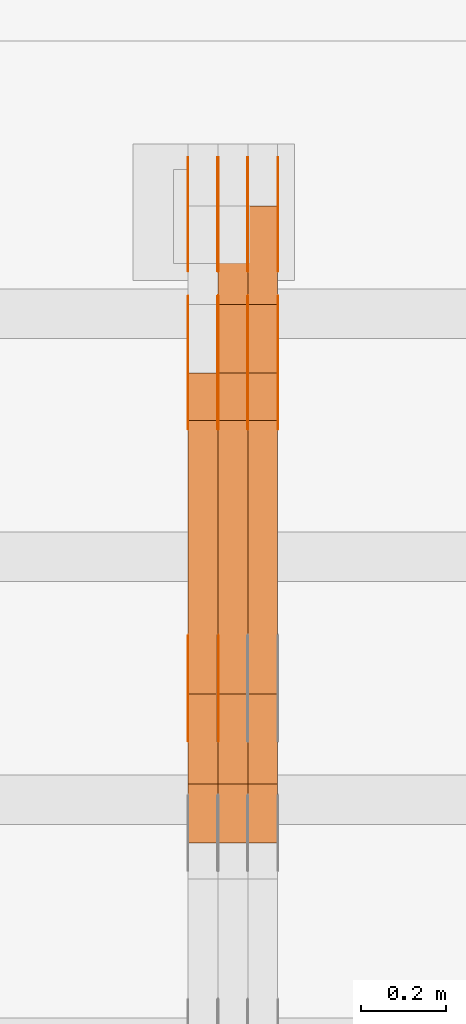
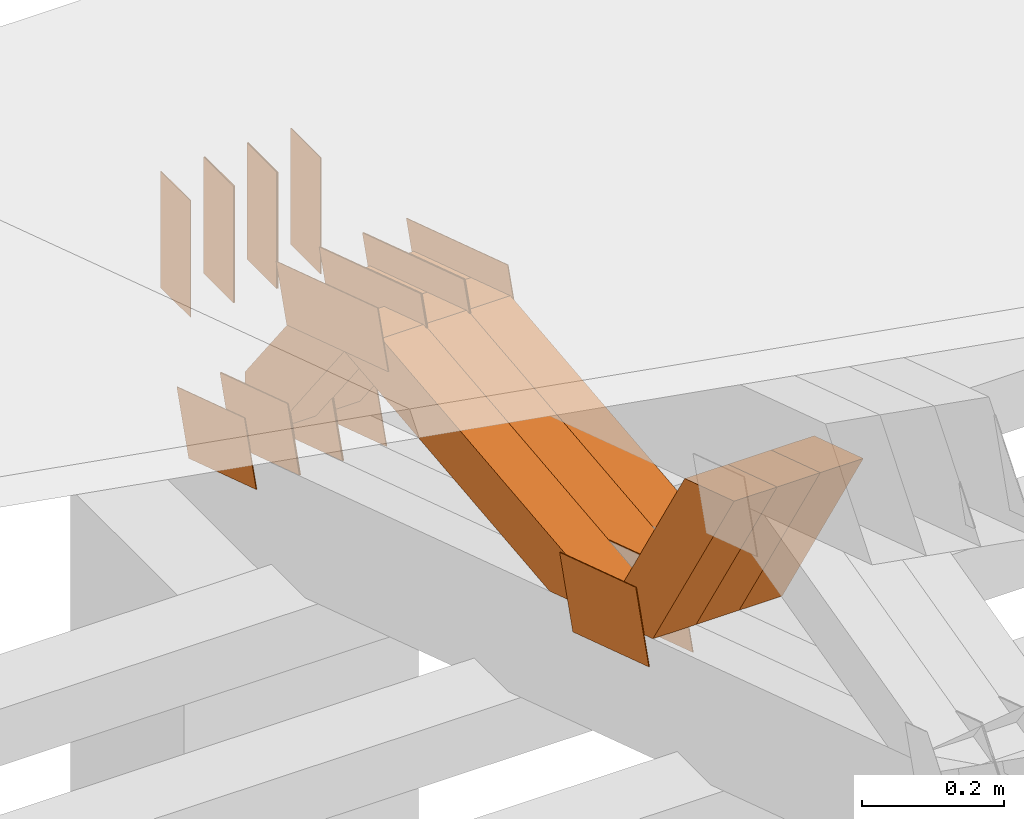
# One storey, part 363 of 385: 28 proxies.
"""IFC2X3 building model written with IfcOpenShell, lengths in millimetres."""

from ifc_helpers import new_model, entity, si_unit, converted_unit, derived_unit, direction, frame, frame_2d, origin, place, context, subcontext, project, spatial, polyline, rectangle, outline, extrude, source, transform, mapped, material, type_object, type_shapes, element, save


model = new_model("IFC2X3")

# Units and contexts
model_context = context("Model", 3, precision=0.01, world=origin(), true_north=direction((6.12303176911189e-17, 1.0)))
body_context = subcontext(model_context, "Body", "Model", "MODEL_VIEW")
ifc_project = project(units=[si_unit("LENGTHUNIT", "METRE", prefix="MILLI"), si_unit("AREAUNIT", "SQUARE_METRE"), si_unit("VOLUMEUNIT", "CUBIC_METRE"), converted_unit("PLANEANGLEUNIT", "DEGREE", entity("IfcRatioMeasure", 0.0174532925199433), si_unit("PLANEANGLEUNIT", "RADIAN"), dimensions=[0, 0, 0, 0, 0, 0, 0]), si_unit("MASSUNIT", "GRAM", prefix="KILO"), derived_unit("MASSDENSITYUNIT", [(si_unit("MASSUNIT", "GRAM", prefix="KILO"), 1), (si_unit("LENGTHUNIT", "METRE"), -3)]), si_unit("TIMEUNIT", "SECOND"), si_unit("FREQUENCYUNIT", "HERTZ"), si_unit("THERMODYNAMICTEMPERATUREUNIT", "DEGREE_CELSIUS"), derived_unit("THERMALTRANSMITTANCEUNIT", [(si_unit("MASSUNIT", "GRAM", prefix="KILO"), 1), (si_unit("THERMODYNAMICTEMPERATUREUNIT", "KELVIN"), -1), (si_unit("TIMEUNIT", "SECOND"), -3)]), derived_unit("VOLUMETRICFLOWRATEUNIT", [(si_unit("LENGTHUNIT", "METRE"), 3), (si_unit("TIMEUNIT", "SECOND"), -1)]), si_unit("ELECTRICCURRENTUNIT", "AMPERE"), si_unit("ELECTRICVOLTAGEUNIT", "VOLT"), si_unit("POWERUNIT", "WATT"), si_unit("FORCEUNIT", "NEWTON", prefix="KILO"), si_unit("ILLUMINANCEUNIT", "LUX"), si_unit("LUMINOUSFLUXUNIT", "LUMEN"), si_unit("LUMINOUSINTENSITYUNIT", "CANDELA"), derived_unit("USERDEFINED", [(si_unit("MASSUNIT", "GRAM", prefix="KILO"), -1), (si_unit("LENGTHUNIT", "METRE"), -2), (si_unit("TIMEUNIT", "SECOND"), 3), (si_unit("LUMINOUSFLUXUNIT", "LUMEN"), 1)]), derived_unit("LINEARVELOCITYUNIT", [(si_unit("LENGTHUNIT", "METRE"), 1), (si_unit("TIMEUNIT", "SECOND"), -1)]), si_unit("PRESSUREUNIT", "PASCAL"), derived_unit("USERDEFINED", [(si_unit("LENGTHUNIT", "METRE"), -2), (si_unit("MASSUNIT", "GRAM", prefix="KILO"), 1), (si_unit("TIMEUNIT", "SECOND"), -2)])], contexts=[model_context])

# Site, building, storey
site_placement = place(None, origin())
site = spatial("IfcSite", under=ifc_project, at=site_placement, CompositionType="ELEMENT")
building_placement = place(site_placement, origin())
building = spatial("IfcBuilding", under=site, at=building_placement, CompositionType="ELEMENT")
storey_placement = place(building_placement, origin())
storey = spatial("IfcBuildingStorey", under=building, at=storey_placement, Name="Default", CompositionType="ELEMENT", Elevation=0.0)

# Proxies
ifc_material_1 = material(Name="IfcSurfaceStyle #550382")
building_element_proxy_type_1 = type_object("IfcBuildingElementProxyType", PredefinedType="NOTDEFINED", material=ifc_material_1)
shared_shape_1 = source(origin(), body_context, "Body", "SweptSolid", [
    extrude(outline(polyline([(-100.000024997547, -54.0000105875654), (100.000088940899, -54.0000105875654), (99.9999100805868, 54.0000105875654), (-99.9999740239394, 54.0000105875654), (-100.000024997547, -54.0000105875654)])), frame((100.000088940899, 54.0000474633838, 0.0), z_axis=(0.0, 0.0, 1.0), x_axis=(-1.0, 0.0, 0.0)), (0.0, 0.0, 1.0), 1.3),
])
type_shapes(building_element_proxy_type_1, [shared_shape_1])
proxy_1_placement = place(building_placement, frame((45386.3, 26390.6212638563, 73.3227520411355), z_axis=(-1.0, 0.0, 0.0), x_axis=(0.0, -0.951056516295124, 0.309016994375039)))
element("IfcBuildingElementProxy", 1, at=proxy_1_placement, inside=storey, type_object=building_element_proxy_type_1, material=ifc_material_1, context=body_context, shape_type="MappedRepresentation", body=[
    mapped(shared_shape_1, transform((0.0, 0.0, 0.0), scale=1.0)),
])
ifc_material_2 = material(Name="IfcSurfaceStyle #550325")
building_element_proxy_type_2 = type_object("IfcBuildingElementProxyType", PredefinedType="NOTDEFINED", material=ifc_material_2)
shared_shape_2 = source(origin(), body_context, "Body", "SweptSolid", [
    extrude(outline(polyline([(-100.000024997547, -54.0000105875654), (100.000088940899, -54.0000105875654), (99.9999100805868, 54.0000105875654), (-99.9999740239394, 54.0000105875654), (-100.000024997547, -54.0000105875654)])), frame((100.000088940899, 54.0000474633838, 0.0), z_axis=(0.0, 0.0, 1.0), x_axis=(-1.0, 0.0, 0.0)), (0.0, 0.0, 1.0), 1.3),
])
type_shapes(building_element_proxy_type_2, [shared_shape_2])
proxy_2_placement = place(building_placement, frame((45315.0, 26390.6212638563, 73.3227520411355), z_axis=(-1.0, 0.0, 0.0), x_axis=(0.0, -0.951056516295124, 0.309016994375039)))
element("IfcBuildingElementProxy", 2, at=proxy_2_placement, inside=storey, type_object=building_element_proxy_type_2, material=ifc_material_2, context=body_context, shape_type="MappedRepresentation", body=[
    mapped(shared_shape_2, transform((0.0, 0.0, 0.0), scale=1.0)),
])
ifc_material_3 = material(Name="IfcSurfaceStyle #550268")
building_element_proxy_type_3 = type_object("IfcBuildingElementProxyType", PredefinedType="NOTDEFINED", material=ifc_material_3)
shared_shape_3 = source(origin(), body_context, "Body", "SweptSolid", [
    extrude(outline(polyline([(-100.000024997547, -54.0000105875654), (100.000088940899, -54.0000105875654), (99.9999100805868, 54.0000105875654), (-99.9999740239394, 54.0000105875654), (-100.000024997547, -54.0000105875654)])), frame((100.000088940899, 54.0000474633838, 0.0), z_axis=(0.0, 0.0, 1.0), x_axis=(-1.0, 0.0, 0.0)), (0.0, 0.0, 1.0), 1.3),
])
type_shapes(building_element_proxy_type_3, [shared_shape_3])
proxy_3_placement = place(building_placement, frame((45316.3, 26390.6212638563, 73.3227520411355), z_axis=(-1.0, 0.0, 0.0), x_axis=(0.0, -0.951056516295124, 0.309016994375039)))
element("IfcBuildingElementProxy", 3, at=proxy_3_placement, inside=storey, type_object=building_element_proxy_type_3, material=ifc_material_3, context=body_context, shape_type="MappedRepresentation", body=[
    mapped(shared_shape_3, transform((0.0, 0.0, 0.0), scale=1.0)),
])
ifc_material_4 = material(Name="IfcSurfaceStyle #550211")
building_element_proxy_type_4 = type_object("IfcBuildingElementProxyType", PredefinedType="NOTDEFINED", material=ifc_material_4)
shared_shape_4 = source(origin(), body_context, "Body", "SweptSolid", [
    extrude(outline(polyline([(-100.000024997547, -54.0000105875654), (100.000088940899, -54.0000105875654), (99.9999100805868, 54.0000105875654), (-99.9999740239394, 54.0000105875654), (-100.000024997547, -54.0000105875654)])), frame((100.000088940899, 54.0000474633838, 0.0), z_axis=(0.0, 0.0, 1.0), x_axis=(-1.0, 0.0, 0.0)), (0.0, 0.0, 1.0), 1.29999999999998),
])
type_shapes(building_element_proxy_type_4, [shared_shape_4])
proxy_4_placement = place(building_placement, frame((45245.0, 26390.6212638563, 73.3227520411355), z_axis=(-1.0, 0.0, 0.0), x_axis=(0.0, -0.951056516295124, 0.309016994375039)))
element("IfcBuildingElementProxy", 4, at=proxy_4_placement, inside=storey, type_object=building_element_proxy_type_4, material=ifc_material_4, context=body_context, shape_type="MappedRepresentation", body=[
    mapped(shared_shape_4, transform((0.0, 0.0, 0.0), scale=1.0)),
])
ifc_material_5 = material(Name="IfcSurfaceStyle #550154")
building_element_proxy_type_5 = type_object("IfcBuildingElementProxyType", PredefinedType="NOTDEFINED", material=ifc_material_5)
shared_shape_5 = source(origin(), body_context, "Body", "SweptSolid", [
    extrude(outline(polyline([(-100.000024997547, -54.0000105875654), (100.000088940899, -54.0000105875654), (99.9999100805868, 54.0000105875654), (-99.9999740239394, 54.0000105875654), (-100.000024997547, -54.0000105875654)])), frame((100.000088940899, 54.0000474633838, 0.0), z_axis=(0.0, 0.0, 1.0), x_axis=(-1.0, 0.0, 0.0)), (0.0, 0.0, 1.0), 1.29999999999998),
])
type_shapes(building_element_proxy_type_5, [shared_shape_5])
proxy_5_placement = place(building_placement, frame((45246.3, 26390.6212638563, 73.3227520411355), z_axis=(-1.0, 0.0, 0.0), x_axis=(0.0, -0.951056516295124, 0.309016994375039)))
element("IfcBuildingElementProxy", 5, at=proxy_5_placement, inside=storey, type_object=building_element_proxy_type_5, material=ifc_material_5, context=body_context, shape_type="MappedRepresentation", body=[
    mapped(shared_shape_5, transform((0.0, 0.0, 0.0), scale=1.0)),
])
ifc_material_6 = material(Name="IfcSurfaceStyle #550097")
building_element_proxy_type_6 = type_object("IfcBuildingElementProxyType", PredefinedType="NOTDEFINED", material=ifc_material_6)
shared_shape_6 = source(origin(), body_context, "Body", "SweptSolid", [
    extrude(outline(polyline([(-100.000024997547, -54.0000105875654), (100.000088940899, -54.0000105875654), (99.9999100805868, 54.0000105875654), (-99.9999740239394, 54.0000105875654), (-100.000024997547, -54.0000105875654)])), frame((100.000088940899, 54.0000474633838, 0.0), z_axis=(0.0, 0.0, 1.0), x_axis=(-1.0, 0.0, 0.0)), (0.0, 0.0, 1.0), 1.29999999999999),
])
type_shapes(building_element_proxy_type_6, [shared_shape_6])
proxy_6_placement = place(building_placement, frame((45175.0, 26390.6212638563, 73.3227520411355), z_axis=(-1.0, 0.0, 0.0), x_axis=(0.0, -0.951056516295124, 0.309016994375039)))
element("IfcBuildingElementProxy", 6, at=proxy_6_placement, inside=storey, type_object=building_element_proxy_type_6, material=ifc_material_6, context=body_context, shape_type="MappedRepresentation", body=[
    mapped(shared_shape_6, transform((0.0, 0.0, 0.0), scale=1.0)),
])
ifc_material_7 = material(Name="IfcSurfaceStyle #538184")
building_element_proxy_type_7 = type_object("IfcBuildingElementProxyType", PredefinedType="NOTDEFINED", material=ifc_material_7)
shared_shape_7 = source(origin(), body_context, "Body", "SweptSolid", [
    extrude(outline(polyline([(-112.50003853564, -60.0000121429077), (112.50002982902, -60.0000121429077), (112.500043250865, 60.0000121429077), (-112.500034544245, 60.0000121429077), (-112.50003853564, -60.0000121429077)])), frame((112.500056021398, 60.0000121429077, 0.0), z_axis=(0.0, 0.0, 1.0), x_axis=(-1.0, 0.0, 0.0)), (0.0, 0.0, 1.0), 1.29999999999998),
])
type_shapes(building_element_proxy_type_7, [shared_shape_7])
proxy_7_placement = place(building_placement, frame((45246.3, 25310.2182710495, 430.675738123044), z_axis=(-1.0, 0.0, 0.0), x_axis=(0.0, -0.951056516295124, 0.309016994375039)))
element("IfcBuildingElementProxy", 7, at=proxy_7_placement, inside=storey, type_object=building_element_proxy_type_7, material=ifc_material_7, context=body_context, shape_type="MappedRepresentation", body=[
    mapped(shared_shape_7, transform((0.0, 0.0, 0.0), scale=1.0)),
])
ifc_material_8 = material(Name="IfcSurfaceStyle #538127")
building_element_proxy_type_8 = type_object("IfcBuildingElementProxyType", PredefinedType="NOTDEFINED", material=ifc_material_8)
shared_shape_8 = source(origin(), body_context, "Body", "SweptSolid", [
    extrude(outline(polyline([(-112.50003853564, -60.0000121429077), (112.50002982902, -60.0000121429077), (112.500043250865, 60.0000121429077), (-112.500034544245, 60.0000121429077), (-112.50003853564, -60.0000121429077)])), frame((112.500056021398, 60.0000121429077, 0.0), z_axis=(0.0, 0.0, 1.0), x_axis=(-1.0, 0.0, 0.0)), (0.0, 0.0, 1.0), 1.29999999999999),
])
type_shapes(building_element_proxy_type_8, [shared_shape_8])
proxy_8_placement = place(building_placement, frame((45175.0, 25310.2182710495, 430.675738123044), z_axis=(-1.0, 0.0, 0.0), x_axis=(0.0, -0.951056516295124, 0.309016994375039)))
element("IfcBuildingElementProxy", 8, at=proxy_8_placement, inside=storey, type_object=building_element_proxy_type_8, material=ifc_material_8, context=body_context, shape_type="MappedRepresentation", body=[
    mapped(shared_shape_8, transform((0.0, 0.0, 0.0), scale=1.0)),
])
ifc_material_9 = material(Name="IfcSurfaceStyle #537728")
building_element_proxy_type_9 = type_object("IfcBuildingElementProxyType", PredefinedType="NOTDEFINED", material=ifc_material_9)
shared_shape_9 = source(origin(), body_context, "Body", "SweptSolid", [
    extrude(outline(polyline([(-149.999901061401, -48.0000057587028), (150.000035297123, -48.0000057587028), (149.999910491851, 48.0000057587028), (-150.000044727574, 48.0000057587028), (-149.999901061401, -48.0000057587028)])), frame((150.000035297123, 48.0000632585775, 0.0), z_axis=(0.0, 0.0, 1.0), x_axis=(-1.0, 0.0, 0.0)), (0.0, 0.0, 1.0), 1.29999999999999),
])
type_shapes(building_element_proxy_type_9, [shared_shape_9])
proxy_9_placement = place(building_placement, frame((45386.3, 26115.0176968219, 469.58296924555), z_axis=(-1.0, 0.0, 0.0), x_axis=(0.0, -0.951056516295154, 0.309016994374948)))
element("IfcBuildingElementProxy", 9, at=proxy_9_placement, inside=storey, type_object=building_element_proxy_type_9, material=ifc_material_9, context=body_context, shape_type="MappedRepresentation", body=[
    mapped(shared_shape_9, transform((0.0, 0.0, 0.0), scale=1.0)),
])
ifc_material_10 = material(Name="IfcSurfaceStyle #537671")
building_element_proxy_type_10 = type_object("IfcBuildingElementProxyType", PredefinedType="NOTDEFINED", material=ifc_material_10)
shared_shape_10 = source(origin(), body_context, "Body", "SweptSolid", [
    extrude(outline(polyline([(-149.999901061401, -48.0000057587028), (150.000035297123, -48.0000057587028), (149.999910491851, 48.0000057587028), (-150.000044727574, 48.0000057587028), (-149.999901061401, -48.0000057587028)])), frame((150.000035297123, 48.0000632585775, 0.0), z_axis=(0.0, 0.0, 1.0), x_axis=(-1.0, 0.0, 0.0)), (0.0, 0.0, 1.0), 1.29999999999999),
])
type_shapes(building_element_proxy_type_10, [shared_shape_10])
proxy_10_placement = place(building_placement, frame((45315.0, 26115.0176968219, 469.58296924555), z_axis=(-1.0, 0.0, 0.0), x_axis=(0.0, -0.951056516295154, 0.309016994374948)))
element("IfcBuildingElementProxy", 10, at=proxy_10_placement, inside=storey, type_object=building_element_proxy_type_10, material=ifc_material_10, context=body_context, shape_type="MappedRepresentation", body=[
    mapped(shared_shape_10, transform((0.0, 0.0, 0.0), scale=1.0)),
])
ifc_material_11 = material(Name="IfcSurfaceStyle #537614")
building_element_proxy_type_11 = type_object("IfcBuildingElementProxyType", PredefinedType="NOTDEFINED", material=ifc_material_11)
shared_shape_11 = source(origin(), body_context, "Body", "SweptSolid", [
    extrude(outline(polyline([(-149.999901061401, -48.0000057587028), (150.000035297123, -48.0000057587028), (149.999910491851, 48.0000057587028), (-150.000044727574, 48.0000057587028), (-149.999901061401, -48.0000057587028)])), frame((150.000035297123, 48.0000632585775, 0.0), z_axis=(0.0, 0.0, 1.0), x_axis=(-1.0, 0.0, 0.0)), (0.0, 0.0, 1.0), 1.29999999999999),
])
type_shapes(building_element_proxy_type_11, [shared_shape_11])
proxy_11_placement = place(building_placement, frame((45316.3, 26115.0176968219, 469.58296924555), z_axis=(-1.0, 0.0, 0.0), x_axis=(0.0, -0.951056516295154, 0.309016994374948)))
element("IfcBuildingElementProxy", 11, at=proxy_11_placement, inside=storey, type_object=building_element_proxy_type_11, material=ifc_material_11, context=body_context, shape_type="MappedRepresentation", body=[
    mapped(shared_shape_11, transform((0.0, 0.0, 0.0), scale=1.0)),
])
ifc_material_12 = material(Name="IfcSurfaceStyle #537557")
building_element_proxy_type_12 = type_object("IfcBuildingElementProxyType", PredefinedType="NOTDEFINED", material=ifc_material_12)
shared_shape_12 = source(origin(), body_context, "Body", "SweptSolid", [
    extrude(outline(polyline([(-149.999901061401, -48.0000057587028), (150.000035297123, -48.0000057587028), (149.999910491851, 48.0000057587028), (-150.000044727574, 48.0000057587028), (-149.999901061401, -48.0000057587028)])), frame((150.000035297123, 48.0000632585775, 0.0), z_axis=(0.0, 0.0, 1.0), x_axis=(-1.0, 0.0, 0.0)), (0.0, 0.0, 1.0), 1.29999999999998),
])
type_shapes(building_element_proxy_type_12, [shared_shape_12])
proxy_12_placement = place(building_placement, frame((45245.0, 26115.0176968219, 469.58296924555), z_axis=(-1.0, 0.0, 0.0), x_axis=(0.0, -0.951056516295154, 0.309016994374948)))
element("IfcBuildingElementProxy", 12, at=proxy_12_placement, inside=storey, type_object=building_element_proxy_type_12, material=ifc_material_12, context=body_context, shape_type="MappedRepresentation", body=[
    mapped(shared_shape_12, transform((0.0, 0.0, 0.0), scale=1.0)),
])
ifc_material_13 = material(Name="IfcSurfaceStyle #537500")
building_element_proxy_type_13 = type_object("IfcBuildingElementProxyType", PredefinedType="NOTDEFINED", material=ifc_material_13)
shared_shape_13 = source(origin(), body_context, "Body", "SweptSolid", [
    extrude(outline(polyline([(-149.999901061401, -48.0000057587028), (150.000035297123, -48.0000057587028), (149.999910491851, 48.0000057587028), (-150.000044727574, 48.0000057587028), (-149.999901061401, -48.0000057587028)])), frame((150.000035297123, 48.0000632585775, 0.0), z_axis=(0.0, 0.0, 1.0), x_axis=(-1.0, 0.0, 0.0)), (0.0, 0.0, 1.0), 1.29999999999998),
])
type_shapes(building_element_proxy_type_13, [shared_shape_13])
proxy_13_placement = place(building_placement, frame((45246.3, 26115.0176968219, 469.58296924555), z_axis=(-1.0, 0.0, 0.0), x_axis=(0.0, -0.951056516295154, 0.309016994374948)))
element("IfcBuildingElementProxy", 13, at=proxy_13_placement, inside=storey, type_object=building_element_proxy_type_13, material=ifc_material_13, context=body_context, shape_type="MappedRepresentation", body=[
    mapped(shared_shape_13, transform((0.0, 0.0, 0.0), scale=1.0)),
])
ifc_material_14 = material(Name="IfcSurfaceStyle #537443")
building_element_proxy_type_14 = type_object("IfcBuildingElementProxyType", PredefinedType="NOTDEFINED", material=ifc_material_14)
shared_shape_14 = source(origin(), body_context, "Body", "SweptSolid", [
    extrude(outline(polyline([(-149.999901061401, -48.0000057587028), (150.000035297123, -48.0000057587028), (149.999910491851, 48.0000057587028), (-150.000044727574, 48.0000057587028), (-149.999901061401, -48.0000057587028)])), frame((150.000035297123, 48.0000632585775, 0.0), z_axis=(0.0, 0.0, 1.0), x_axis=(-1.0, 0.0, 0.0)), (0.0, 0.0, 1.0), 1.29999999999998),
])
type_shapes(building_element_proxy_type_14, [shared_shape_14])
proxy_14_placement = place(building_placement, frame((45175.0, 26115.0176968219, 469.58296924555), z_axis=(-1.0, 0.0, 0.0), x_axis=(0.0, -0.951056516295154, 0.309016994374948)))
element("IfcBuildingElementProxy", 14, at=proxy_14_placement, inside=storey, type_object=building_element_proxy_type_14, material=ifc_material_14, context=body_context, shape_type="MappedRepresentation", body=[
    mapped(shared_shape_14, transform((0.0, 0.0, 0.0), scale=1.0)),
])
ifc_material_15 = material(Name="IfcSurfaceStyle #537386")
building_element_proxy_type_15 = type_object("IfcBuildingElementProxyType", PredefinedType="NOTDEFINED", material=ifc_material_15)
shared_shape_15 = source(origin(), body_context, "Body", "SweptSolid", [
    extrude(rectangle(XDim=200.0, YDim=84.0000000000005, at=frame_2d((-2.1316282072803e-14, 1.06581410364015e-14), x_axis=(1.0, 0.0))), frame((100.0, 42.0, 0.0), z_axis=(0.0, 0.0, 1.0), x_axis=(-1.0, 0.0, 0.0)), (0.0, 0.0, 1.0), 1.3),
])
type_shapes(building_element_proxy_type_15, [shared_shape_15])
proxy_15_placement = place(building_placement, frame((45386.3, 26469.5000000002, 518.521545410156), z_axis=(-1.0, 0.0, 0.0), x_axis=(0.0, 0.0, -1.0)))
element("IfcBuildingElementProxy", 15, at=proxy_15_placement, inside=storey, type_object=building_element_proxy_type_15, material=ifc_material_15, context=body_context, shape_type="MappedRepresentation", body=[
    mapped(shared_shape_15, transform((0.0, 0.0, 0.0), scale=1.0)),
])
ifc_material_16 = material(Name="IfcSurfaceStyle #537329")
building_element_proxy_type_16 = type_object("IfcBuildingElementProxyType", PredefinedType="NOTDEFINED", material=ifc_material_16)
shared_shape_16 = source(origin(), body_context, "Body", "SweptSolid", [
    extrude(rectangle(XDim=200.0, YDim=84.0000000000005, at=frame_2d((-2.1316282072803e-14, 1.06581410364015e-14), x_axis=(1.0, 0.0))), frame((100.0, 42.0, 0.0), z_axis=(0.0, 0.0, 1.0), x_axis=(-1.0, 0.0, 0.0)), (0.0, 0.0, 1.0), 1.3),
])
type_shapes(building_element_proxy_type_16, [shared_shape_16])
proxy_16_placement = place(building_placement, frame((45315.0, 26469.5000000002, 518.521545410156), z_axis=(-1.0, 0.0, 0.0), x_axis=(0.0, 0.0, -1.0)))
element("IfcBuildingElementProxy", 16, at=proxy_16_placement, inside=storey, type_object=building_element_proxy_type_16, material=ifc_material_16, context=body_context, shape_type="MappedRepresentation", body=[
    mapped(shared_shape_16, transform((0.0, 0.0, 0.0), scale=1.0)),
])
ifc_material_17 = material(Name="IfcSurfaceStyle #537272")
building_element_proxy_type_17 = type_object("IfcBuildingElementProxyType", PredefinedType="NOTDEFINED", material=ifc_material_17)
shared_shape_17 = source(origin(), body_context, "Body", "SweptSolid", [
    extrude(rectangle(XDim=200.0, YDim=84.0000000000005, at=frame_2d((-2.1316282072803e-14, 1.06581410364015e-14), x_axis=(1.0, 0.0))), frame((100.0, 42.0, 0.0), z_axis=(0.0, 0.0, 1.0), x_axis=(-1.0, 0.0, 0.0)), (0.0, 0.0, 1.0), 1.3),
])
type_shapes(building_element_proxy_type_17, [shared_shape_17])
proxy_17_placement = place(building_placement, frame((45316.3, 26469.5000000002, 518.521545410156), z_axis=(-1.0, 0.0, 0.0), x_axis=(0.0, 0.0, -1.0)))
element("IfcBuildingElementProxy", 17, at=proxy_17_placement, inside=storey, type_object=building_element_proxy_type_17, material=ifc_material_17, context=body_context, shape_type="MappedRepresentation", body=[
    mapped(shared_shape_17, transform((0.0, 0.0, 0.0), scale=1.0)),
])
ifc_material_18 = material(Name="IfcSurfaceStyle #537215")
building_element_proxy_type_18 = type_object("IfcBuildingElementProxyType", PredefinedType="NOTDEFINED", material=ifc_material_18)
shared_shape_18 = source(origin(), body_context, "Body", "SweptSolid", [
    extrude(rectangle(XDim=200.0, YDim=84.0000000000005, at=frame_2d((-2.1316282072803e-14, 1.06581410364015e-14), x_axis=(1.0, 0.0))), frame((100.0, 42.0, 0.0), z_axis=(0.0, 0.0, 1.0), x_axis=(-1.0, 0.0, 0.0)), (0.0, 0.0, 1.0), 1.29999999999998),
])
type_shapes(building_element_proxy_type_18, [shared_shape_18])
proxy_18_placement = place(building_placement, frame((45245.0, 26469.5000000002, 518.521545410156), z_axis=(-1.0, 0.0, 0.0), x_axis=(0.0, 0.0, -1.0)))
element("IfcBuildingElementProxy", 18, at=proxy_18_placement, inside=storey, type_object=building_element_proxy_type_18, material=ifc_material_18, context=body_context, shape_type="MappedRepresentation", body=[
    mapped(shared_shape_18, transform((0.0, 0.0, 0.0), scale=1.0)),
])
ifc_material_19 = material(Name="IfcSurfaceStyle #537158")
building_element_proxy_type_19 = type_object("IfcBuildingElementProxyType", PredefinedType="NOTDEFINED", material=ifc_material_19)
shared_shape_19 = source(origin(), body_context, "Body", "SweptSolid", [
    extrude(rectangle(XDim=200.0, YDim=84.0000000000005, at=frame_2d((-2.1316282072803e-14, 1.06581410364015e-14), x_axis=(1.0, 0.0))), frame((100.0, 42.0, 0.0), z_axis=(0.0, 0.0, 1.0), x_axis=(-1.0, 0.0, 0.0)), (0.0, 0.0, 1.0), 1.29999999999998),
])
type_shapes(building_element_proxy_type_19, [shared_shape_19])
proxy_19_placement = place(building_placement, frame((45246.3, 26469.5000000002, 518.521545410156), z_axis=(-1.0, 0.0, 0.0), x_axis=(0.0, 0.0, -1.0)))
element("IfcBuildingElementProxy", 19, at=proxy_19_placement, inside=storey, type_object=building_element_proxy_type_19, material=ifc_material_19, context=body_context, shape_type="MappedRepresentation", body=[
    mapped(shared_shape_19, transform((0.0, 0.0, 0.0), scale=1.0)),
])
ifc_material_20 = material(Name="IfcSurfaceStyle #537101")
building_element_proxy_type_20 = type_object("IfcBuildingElementProxyType", PredefinedType="NOTDEFINED", material=ifc_material_20)
shared_shape_20 = source(origin(), body_context, "Body", "SweptSolid", [
    extrude(rectangle(XDim=200.0, YDim=84.0000000000005, at=frame_2d((-2.1316282072803e-14, 1.06581410364015e-14), x_axis=(1.0, 0.0))), frame((100.0, 42.0, 0.0), z_axis=(0.0, 0.0, 1.0), x_axis=(-1.0, 0.0, 0.0)), (0.0, 0.0, 1.0), 1.29999999999999),
])
type_shapes(building_element_proxy_type_20, [shared_shape_20])
proxy_20_placement = place(building_placement, frame((45175.0, 26469.5000000002, 518.521545410156), z_axis=(-1.0, 0.0, 0.0), x_axis=(0.0, 0.0, -1.0)))
element("IfcBuildingElementProxy", 20, at=proxy_20_placement, inside=storey, type_object=building_element_proxy_type_20, material=ifc_material_20, context=body_context, shape_type="MappedRepresentation", body=[
    mapped(shared_shape_20, transform((0.0, 0.0, 0.0), scale=1.0)),
])
ifc_material_21 = material(Name="IfcSurfaceStyle #526370")
building_element_proxy_type_21 = type_object("IfcBuildingElementProxyType", Name="T1-W31 526368", PredefinedType="NOTDEFINED", material=ifc_material_21)
shared_shape_21 = source(origin(), body_context, "Body", "SweptSolid", [
    extrude(outline(polyline([(-201.245318299844, -47.5000121670808), (204.413774229459, -47.5000121670808), (182.034306640891, 5.35692244583164e-05), (126.70380769348, 47.4999853824686), (-311.906570263987, 47.4999853824686), (-201.245318299844, -47.5000121670808)])), frame((204.413774229459, 47.5002684334588, 0.0), z_axis=(0.0, 0.0, 1.0), x_axis=(-1.0, 0.0, 0.0)), (0.0, 0.0, 1.0), 70.0),
])
type_shapes(building_element_proxy_type_21, [shared_shape_21])
proxy_21_placement = place(building_placement, frame((45385.0, 25127.5652647985, 487.27008059185), z_axis=(-1.0, 0.0, 0.0), x_axis=(0.0, -0.520333970303023, 0.853962855953755)))
element("IfcBuildingElementProxy", 21, at=proxy_21_placement, inside=storey, type_object=building_element_proxy_type_21, material=ifc_material_21, Name="T1-W31", context=body_context, shape_type="MappedRepresentation", body=[
    mapped(shared_shape_21, transform((0.0, 0.0, 0.0), scale=1.0)),
])
ifc_material_22 = material(Name="IfcSurfaceStyle #526304")
building_element_proxy_type_22 = type_object("IfcBuildingElementProxyType", Name="T1-W31 526302", PredefinedType="NOTDEFINED", material=ifc_material_22)
shared_shape_22 = source(origin(), body_context, "Body", "SweptSolid", [
    extrude(outline(polyline([(-201.245318299844, -47.5000121670808), (204.413774229459, -47.5000121670808), (182.034306640891, 5.35692244583164e-05), (126.70380769348, 47.4999853824686), (-311.906570263987, 47.4999853824686), (-201.245318299844, -47.5000121670808)])), frame((204.413774229459, 47.5002684334588, 0.0), z_axis=(0.0, 0.0, 1.0), x_axis=(-1.0, 0.0, 0.0)), (0.0, 0.0, 1.0), 70.0),
])
type_shapes(building_element_proxy_type_22, [shared_shape_22])
proxy_22_placement = place(building_placement, frame((45315.0, 25127.5652647985, 487.27008059185), z_axis=(-1.0, 0.0, 0.0), x_axis=(0.0, -0.520333970303023, 0.853962855953755)))
element("IfcBuildingElementProxy", 22, at=proxy_22_placement, inside=storey, type_object=building_element_proxy_type_22, material=ifc_material_22, Name="T1-W31", context=body_context, shape_type="MappedRepresentation", body=[
    mapped(shared_shape_22, transform((0.0, 0.0, 0.0), scale=1.0)),
])
ifc_material_23 = material(Name="IfcSurfaceStyle #526238")
building_element_proxy_type_23 = type_object("IfcBuildingElementProxyType", Name="T1-W31 526236", PredefinedType="NOTDEFINED", material=ifc_material_23)
shared_shape_23 = source(origin(), body_context, "Body", "SweptSolid", [
    extrude(outline(polyline([(-201.245318299844, -47.5000121670808), (204.413774229459, -47.5000121670808), (182.034306640891, 5.35692244583164e-05), (126.70380769348, 47.4999853824686), (-311.906570263987, 47.4999853824686), (-201.245318299844, -47.5000121670808)])), frame((204.413774229459, 47.5002684334588, 0.0), z_axis=(0.0, 0.0, 1.0), x_axis=(-1.0, 0.0, 0.0)), (0.0, 0.0, 1.0), 70.0),
])
type_shapes(building_element_proxy_type_23, [shared_shape_23])
proxy_23_placement = place(building_placement, frame((45245.0, 25127.5652647985, 487.27008059185), z_axis=(-1.0, 0.0, 0.0), x_axis=(0.0, -0.520333970303023, 0.853962855953755)))
element("IfcBuildingElementProxy", 23, at=proxy_23_placement, inside=storey, type_object=building_element_proxy_type_23, material=ifc_material_23, Name="T1-W31", context=body_context, shape_type="MappedRepresentation", body=[
    mapped(shared_shape_23, transform((0.0, 0.0, 0.0), scale=1.0)),
])
ifc_material_24 = material(Name="IfcSurfaceStyle #525974")
building_element_proxy_type_24 = type_object("IfcBuildingElementProxyType", Name="T1-W4 525972", PredefinedType="NOTDEFINED", material=ifc_material_24)
shared_shape_24 = source(origin(), body_context, "Body", "SweptSolid", [
    extrude(outline(polyline([(-510.077325435179, -47.4999981284922), (188.854793418912, -47.4999981284922), (294.906688207675, 1.67015383116809e-05), (324.289382923648, 47.499989777723), (-297.973539115057, 47.4999897777231), (-510.077325435179, -47.4999981284922)])), frame((324.289382923648, 47.5000278316275, 0.0), z_axis=(0.0, 0.0, 1.0), x_axis=(-1.0, 0.0, 0.0)), (0.0, 0.0, 1.0), 70.0),
])
type_shapes(building_element_proxy_type_24, [shared_shape_24])
proxy_24_placement = place(building_placement, frame((45385.0, 25996.2241251556, 525.69905884318), z_axis=(-1.0, 0.0, 0.0), x_axis=(0.0, -0.994287125203057, -0.106738524701444)))
element("IfcBuildingElementProxy", 24, at=proxy_24_placement, inside=storey, type_object=building_element_proxy_type_24, material=ifc_material_24, Name="T1-W4", context=body_context, shape_type="MappedRepresentation", body=[
    mapped(shared_shape_24, transform((0.0, 0.0, 0.0), scale=1.0)),
])
ifc_material_25 = material(Name="IfcSurfaceStyle #525908")
building_element_proxy_type_25 = type_object("IfcBuildingElementProxyType", Name="T1-W4 525906", PredefinedType="NOTDEFINED", material=ifc_material_25)
shared_shape_25 = source(origin(), body_context, "Body", "SweptSolid", [
    extrude(outline(polyline([(-510.077325435179, -47.4999981284922), (188.854793418912, -47.4999981284922), (294.906688207675, 1.67015383116809e-05), (324.289382923648, 47.499989777723), (-297.973539115057, 47.4999897777231), (-510.077325435179, -47.4999981284922)])), frame((324.289382923648, 47.5000278316275, 0.0), z_axis=(0.0, 0.0, 1.0), x_axis=(-1.0, 0.0, 0.0)), (0.0, 0.0, 1.0), 70.0),
])
type_shapes(building_element_proxy_type_25, [shared_shape_25])
proxy_25_placement = place(building_placement, frame((45315.0, 25996.2241251556, 525.69905884318), z_axis=(-1.0, 0.0, 0.0), x_axis=(0.0, -0.994287125203057, -0.106738524701444)))
element("IfcBuildingElementProxy", 25, at=proxy_25_placement, inside=storey, type_object=building_element_proxy_type_25, material=ifc_material_25, Name="T1-W4", context=body_context, shape_type="MappedRepresentation", body=[
    mapped(shared_shape_25, transform((0.0, 0.0, 0.0), scale=1.0)),
])
ifc_material_26 = material(Name="IfcSurfaceStyle #525842")
building_element_proxy_type_26 = type_object("IfcBuildingElementProxyType", Name="T1-W4 525840", PredefinedType="NOTDEFINED", material=ifc_material_26)
shared_shape_26 = source(origin(), body_context, "Body", "SweptSolid", [
    extrude(outline(polyline([(-510.077325435179, -47.4999981284922), (188.854793418912, -47.4999981284922), (294.906688207675, 1.67015383116809e-05), (324.289382923648, 47.499989777723), (-297.973539115057, 47.4999897777231), (-510.077325435179, -47.4999981284922)])), frame((324.289382923648, 47.5000278316275, 0.0), z_axis=(0.0, 0.0, 1.0), x_axis=(-1.0, 0.0, 0.0)), (0.0, 0.0, 1.0), 70.0),
])
type_shapes(building_element_proxy_type_26, [shared_shape_26])
proxy_26_placement = place(building_placement, frame((45245.0, 25996.2241251556, 525.69905884318), z_axis=(-1.0, 0.0, 0.0), x_axis=(0.0, -0.994287125203057, -0.106738524701444)))
element("IfcBuildingElementProxy", 26, at=proxy_26_placement, inside=storey, type_object=building_element_proxy_type_26, material=ifc_material_26, Name="T1-W4", context=body_context, shape_type="MappedRepresentation", body=[
    mapped(shared_shape_26, transform((0.0, 0.0, 0.0), scale=1.0)),
])
ifc_material_27 = material(Name="IfcSurfaceStyle #525578")
building_element_proxy_type_27 = type_object("IfcBuildingElementProxyType", Name="T1-W21 525576", PredefinedType="NOTDEFINED", material=ifc_material_27)
shared_shape_27 = source(origin(), body_context, "Body", "SweptSolid", [
    extrude(outline(polyline([(-209.199362597501, -47.5000308982766), (168.813164734153, -47.5000308982766), (229.900717355638, -2.18385470334148e-05), (159.828709317766, 47.5000418175501), (-349.343228810055, 47.5000418175502), (-209.199362597501, -47.5000308982766)])), frame((229.900720156071, 47.5000418175501, 0.0), z_axis=(0.0, 0.0, 1.0), x_axis=(-1.0, 0.0, 0.0)), (0.0, 0.0, 1.0), 70.0),
])
type_shapes(building_element_proxy_type_27, [shared_shape_27])
proxy_27_placement = place(building_placement, frame((45385.0, 26317.5019908272, 112.518372832984), z_axis=(-1.0, 0.0, 0.0), x_axis=(0.0, -0.613839629272042, 0.789430750310097)))
element("IfcBuildingElementProxy", 27, at=proxy_27_placement, inside=storey, type_object=building_element_proxy_type_27, material=ifc_material_27, Name="T1-W21", context=body_context, shape_type="MappedRepresentation", body=[
    mapped(shared_shape_27, transform((0.0, 0.0, 0.0), scale=1.0)),
])
ifc_material_28 = material(Name="IfcSurfaceStyle #525512")
building_element_proxy_type_28 = type_object("IfcBuildingElementProxyType", Name="T1-W21 525510", PredefinedType="NOTDEFINED", material=ifc_material_28)
shared_shape_28 = source(origin(), body_context, "Body", "SweptSolid", [
    extrude(outline(polyline([(-209.199362597501, -47.5000308982766), (168.813164734153, -47.5000308982766), (229.900717355638, -2.18385470334148e-05), (159.828709317766, 47.5000418175501), (-349.343228810055, 47.5000418175502), (-209.199362597501, -47.5000308982766)])), frame((229.900720156071, 47.5000418175501, 0.0), z_axis=(0.0, 0.0, 1.0), x_axis=(-1.0, 0.0, 0.0)), (0.0, 0.0, 1.0), 70.0),
])
type_shapes(building_element_proxy_type_28, [shared_shape_28])
proxy_28_placement = place(building_placement, frame((45315.0, 26317.5019908272, 112.518372832984), z_axis=(-1.0, 0.0, 0.0), x_axis=(0.0, -0.613839629272042, 0.789430750310097)))
element("IfcBuildingElementProxy", 28, at=proxy_28_placement, inside=storey, type_object=building_element_proxy_type_28, material=ifc_material_28, Name="T1-W21", context=body_context, shape_type="MappedRepresentation", body=[
    mapped(shared_shape_28, transform((0.0, 0.0, 0.0), scale=1.0)),
])

save(model, "model.ifc")
